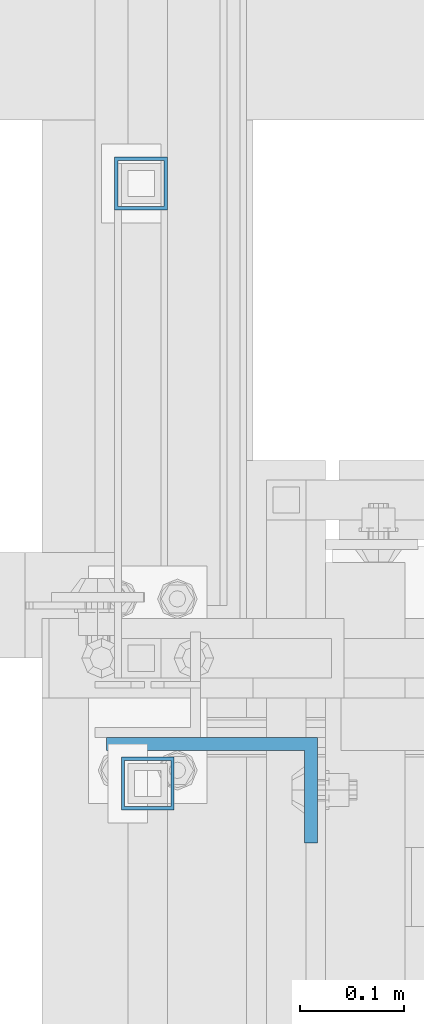
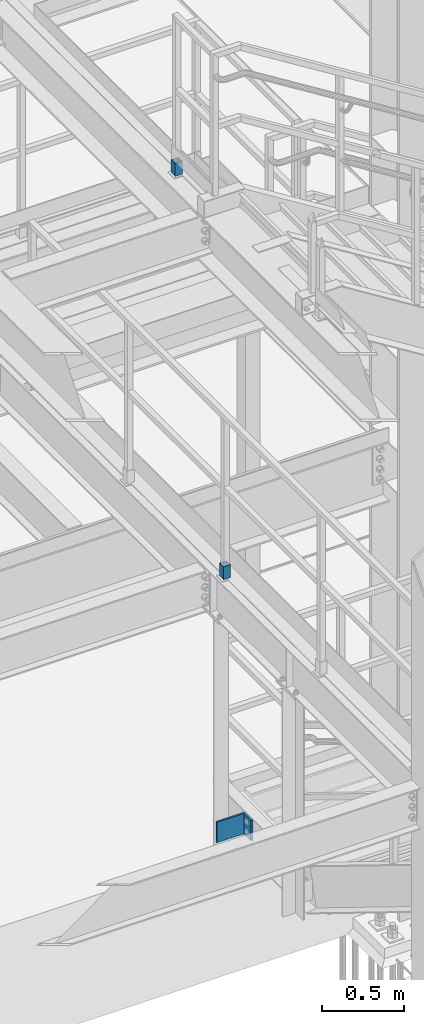
# One storey, part 1478 of 3843: 3 columns, 3 elements without a shape of their own.
"""IFC2X3 building model written with IfcOpenShell, lengths in millimetres."""

import ifcopenshell
import ifcopenshell.guid

model = None  # the IFC model being written
_history = None  # IfcOwnerHistory: only IFC2X3 demands one
_inside = {}  # id of a spatial element -> (the spatial element, [elements in it])
_under = {}  # id of a project, library or spatial element -> (it, [spatial elements below it])
_declared = {}  # id of a project -> (the project, [libraries it declares])
_typed = {}  # id of a type object -> (the type object, [elements of that type])
_made_of = {}  # id of a material, layer set ... -> (it, [elements and type objects made of it])


def new_model(schema):
    """Start an empty IFC model of exactly this schema.

    Asked for "IFC4X3", IfcOpenShell would pick the latest addendum, in which some entities
    have other attributes; the version numbers below select the first issue.
    IFC2X3 requires an IfcOwnerHistory on every rooted entity: one is made here for all.
    """
    global model, _history
    if schema == "IFC4X3":
        model = ifcopenshell.file(schema_version=(4, 3, 0, 0))
    else:
        model = ifcopenshell.file(schema=schema)
    _inside.clear()
    _under.clear()
    _declared.clear()
    _typed.clear()
    _made_of.clear()
    _history = None
    if model.schema == "IFC2X3":
        org = make("IfcOrganization", Name="unknown")
        user = make(
            "IfcPersonAndOrganization",
            ThePerson=make("IfcPerson", FamilyName="unknown"),
            TheOrganization=org,
        )
        app = make(
            "IfcApplication",
            ApplicationDeveloper=org,
            Version="unknown",
            ApplicationFullName="unknown",
            ApplicationIdentifier="unknown",
        )
        _history = make(
            "IfcOwnerHistory",
            OwningUser=user,
            OwningApplication=app,
            ChangeAction="ADDED",
            CreationDate=0,
        )
    return model


def make(cls, **values):
    """One entity of the class cls with the attributes given. An attribute that is None is left unset."""
    return model.create_entity(
        cls, **{name: value for name, value in values.items() if value is not None}
    )


def rooted(cls, **values):
    """An entity with a GlobalId (a new one), such as an element, a storey or a relation."""
    return make(cls, GlobalId=ifcopenshell.guid.new(), OwnerHistory=_history, **values)


def si_unit(unit_type, name, prefix=None):
    """IfcSIUnit, for example si_unit("LENGTHUNIT", "METRE", prefix="MILLI")."""
    return make("IfcSIUnit", UnitType=unit_type, Prefix=prefix, Name=name)


def assignment(units):
    """IfcUnitAssignment: the units of a project."""
    return None if units is None else make("IfcUnitAssignment", Units=units)


def point(xyz):
    """IfcCartesianPoint."""
    return None if xyz is None else make("IfcCartesianPoint", Coordinates=xyz)


def direction(xyz):
    """IfcDirection."""
    return None if xyz is None else make("IfcDirection", DirectionRatios=xyz)


def frame(location, z_axis=None, x_axis=None):
    """IfcAxis2Placement3D, a coordinate frame: its origin and axes. An axis left out is left unset."""
    return make(
        "IfcAxis2Placement3D",
        Location=point(location),
        Axis=direction(z_axis),
        RefDirection=direction(x_axis),
    )


def origin_with_axes():
    """The frame at (0, 0, 0) with the z axis (0, 0, 1) and the x axis (1, 0, 0) written out."""
    return frame((0.0, 0.0, 0.0), z_axis=(0.0, 0.0, 1.0), x_axis=(1.0, 0.0, 0.0))


def place(relative_to, where):
    """IfcLocalPlacement: puts the frame where relative to a parent placement (None: the world)."""
    return make(
        "IfcLocalPlacement", PlacementRelTo=relative_to, RelativePlacement=where
    )


def context(
    kind, dimensions, precision=None, world=None, true_north=None, identifier=None
):
    """IfcGeometricRepresentationContext, for example the 3D "Model" context."""
    return make(
        "IfcGeometricRepresentationContext",
        ContextIdentifier=identifier,
        ContextType=kind,
        CoordinateSpaceDimension=dimensions,
        Precision=precision,
        WorldCoordinateSystem=world,
        TrueNorth=true_north,
    )


def subcontext(parent, identifier, kind, view, scale=None):
    """IfcGeometricRepresentationSubContext, for example "Body" below "Model"."""
    return make(
        "IfcGeometricRepresentationSubContext",
        ContextIdentifier=identifier,
        ContextType=kind,
        ParentContext=parent,
        TargetScale=scale,
        TargetView=view,
    )


def project(units=None, contexts=None):
    """IfcProject with its units and contexts."""
    return rooted(
        "IfcProject",
        Name="project",
        RepresentationContexts=contexts,
        UnitsInContext=assignment(units),
    )


def spatial(cls, under=None, at=None, **own):
    """A site, building, storey or space (cls), placed at a placement, below another one or the project."""
    s = rooted(cls, ObjectPlacement=at, **own)
    if under is not None:
        _under.setdefault(under.id(), (under, []))[1].append(s)
    return s


def faces_of(points, faces, orient=None, outer=None):
    """IfcFace entities. A face is a list of loops; a loop is a list of indices into points, from 0.

    orient and outer hold one flag for each loop. By default every Orientation is true, the
    first loop of a face is its IfcFaceOuterBound and the others are IfcFaceBound.
    """
    made = []
    for i, loops in enumerate(faces):
        bounds = []
        for j, loop in enumerate(loops):
            is_outer = j == 0 if outer is None else outer[i][j]
            bounds.append(
                make(
                    "IfcFaceOuterBound" if is_outer else "IfcFaceBound",
                    Bound=make("IfcPolyLoop", Polygon=[points[k] for k in loop]),
                    Orientation=True if orient is None else orient[i][j],
                )
            )
        made.append(make("IfcFace", Bounds=bounds))
    return made


def faceted_brep(points, faces, orient=None, outer=None, voids=None):
    """IfcFacetedBrep: a solid bounded by flat faces; with voids (closed shells), ...WithVoids."""
    shared = [point(p) for p in points]
    hull = make("IfcClosedShell", CfsFaces=faces_of(shared, faces, orient, outer))
    if voids is None:
        return make("IfcFacetedBrep", Outer=hull)
    return make(
        "IfcFacetedBrepWithVoids",
        Outer=hull,
        Voids=[
            make(cls, CfsFaces=faces_of(shared, fs, o, b)) for cls, fs, o, b in voids
        ],
    )


def shape(context_of_items, identifier, shape_type, items):
    """IfcShapeRepresentation: the items that make up one representation, for example the "Body"."""
    return make(
        "IfcShapeRepresentation",
        ContextOfItems=context_of_items,
        RepresentationIdentifier=identifier,
        RepresentationType=shape_type,
        Items=items,
    )


def material(Name=None, Category=None):
    """IfcMaterial."""
    return make("IfcMaterial", Name=Name, Category=Category)


def made_of(thing, what):
    """Note that an element or type object is made of a material, layer set ...; save() writes the relation."""
    if what is not None:
        _made_of.setdefault(what.id(), (what, []))[1].append(thing)
    return thing


def type_object(cls, material=None, **own):
    """A type object (cls), such as IfcWallType, which elements share."""
    return made_of(rooted(cls, **own), material)


def element(
    cls,
    number,
    at=None,
    inside=None,
    cuts=None,
    type_object=None,
    material=None,
    context=None,
    identifier="Body",
    shape_type=None,
    held_by="IfcProductDefinitionShape",
    body=None,
    shapes=None,
    **own,
):
    """One element of the class cls, such as IfcWall. Its Tag is "e" and its number.

    at: its placement. inside: the storey or other place that contains it. cuts: it is an
    opening in that element (IfcRelVoidsElement). A single representation is given by context,
    identifier, shape_type and body (its items); several are given by shapes. held_by: the class
    of the entity that holds the representations. save() writes the other relations.
    """
    e = rooted(cls, Tag="e%d" % number, ObjectPlacement=at, **own)
    if body is not None:
        shapes = [shape(context, identifier, shape_type, body)]
    if shapes is not None:
        e.Representation = make(held_by, Representations=shapes)
    if inside is not None:
        _inside.setdefault(inside.id(), (inside, []))[1].append(e)
    if cuts is not None:
        rooted(
            "IfcRelVoidsElement", RelatingBuildingElement=cuts, RelatedOpeningElement=e
        )
    if type_object is not None:
        _typed.setdefault(type_object.id(), (type_object, []))[1].append(e)
    return made_of(e, material)


def aggregate(whole, parts):
    """IfcRelAggregates: a whole, such as a stair, and the parts it consists of."""
    return rooted("IfcRelAggregates", RelatingObject=whole, RelatedObjects=parts)


def save(model, path):
    """Write the relations noted so far, then the file.

    IfcRelAggregates (storeys below a building ...), IfcRelContainedInSpatialStructure (elements
    in a storey), IfcRelDefinesByType, IfcRelAssociatesMaterial and IfcRelDeclares: one each for
    every whole, place, type object, material and project.
    """
    for whole, parts in _under.values():
        aggregate(whole, parts)
    for where, things in _inside.values():
        rooted(
            "IfcRelContainedInSpatialStructure",
            RelatedElements=things,
            RelatingStructure=where,
        )
    for kind, things in _typed.values():
        rooted("IfcRelDefinesByType", RelatedObjects=things, RelatingType=kind)
    for what, things in _made_of.values():
        rooted("IfcRelAssociatesMaterial", RelatedObjects=things, RelatingMaterial=what)
    for by, libraries in _declared.values():
        rooted("IfcRelDeclares", RelatingContext=by, RelatedDefinitions=libraries)
    model.write(path)


model = new_model("IFC2X3")

# Units and contexts
model_context = context("Model", 3, precision=1e-05, world=origin_with_axes())
body_context = subcontext(model_context, "Body", "Model", "MODEL_VIEW")
ifc_project = project(units=[si_unit("LENGTHUNIT", "METRE", prefix="MILLI"), si_unit("AREAUNIT", "SQUARE_METRE"), si_unit("VOLUMEUNIT", "CUBIC_METRE"), si_unit("MASSUNIT", "GRAM", prefix="KILO"), si_unit("TIMEUNIT", "SECOND"), si_unit("PLANEANGLEUNIT", "RADIAN"), si_unit("SOLIDANGLEUNIT", "STERADIAN"), si_unit("THERMODYNAMICTEMPERATUREUNIT", "DEGREE_CELSIUS"), si_unit("LUMINOUSINTENSITYUNIT", "LUMEN")], contexts=[model_context])

# Site, building, storey
site_placement = place(None, origin_with_axes())
site = spatial("IfcSite", under=ifc_project, at=site_placement, CompositionType="ELEMENT")
building_placement = place(site_placement, origin_with_axes())
building = spatial("IfcBuilding", under=site, at=building_placement, Name="Undefined", CompositionType="ELEMENT")
storey_placement = place(building_placement, origin_with_axes())
storey = spatial("IfcBuildingStorey", under=building, at=storey_placement, Name="Undefined", CompositionType="ELEMENT", Elevation=0.0)

# Assembly, column
assembly_1_placement = place(storey_placement, origin_with_axes())
assembly_1 = element("IfcElementAssembly", 1, at=assembly_1_placement, inside=storey, Name="BEAM", AssemblyPlace="NOTDEFINED", PredefinedType="RIGID_FRAME")
ifc_material_1 = material()
column_type_1 = type_object("IfcColumnType", Name="HSS2X2X1/8", PredefinedType="NOTDEFINED")
column_1_placement = place(assembly_1_placement, frame((52990.75, 22790.1499996175, 34817.05), z_axis=(1.0, 0.0, 0.0), x_axis=(0.0, 0.0, 1.0)))
column_1 = element("IfcColumn", 2, at=column_1_placement, type_object=column_type_1, material=ifc_material_1, Name="POST_SLEEVE", ObjectType="HSS2X2X1/8", context=body_context, shape_type="Brep", body=[
    faceted_brep([(0.0, 22.2249999999985, -22.2249999999985), (0.0, -22.2249999999985, -22.2249999999985), (95.25, -22.2249999999985, -22.2249999999985), (95.25, 22.2249999999985, -22.2249999999985), (0.0, -22.2249999999985, 22.2249999999985), (95.25, -22.2249999999985, 22.2249999999985), (0.0, 22.2249999999985, 22.2249999999985), (95.25, 22.2249999999985, 22.2249999999985), (0.0, 25.4000000000015, -25.4000000000015), (0.0, 25.4000000000015, 25.4000000000015), (95.25, 25.4000000000015, 25.4000000000015), (95.25, 25.4000000000015, -25.4000000000015), (0.0, -25.4000000000015, 25.4000000000015), (95.25, -25.4000000000015, 25.4000000000015), (0.0, -25.4000000000015, -25.4000000000015), (95.25, -25.4000000000015, -25.4000000000015)], [[[0, 1, 2, 3]], [[1, 4, 5, 2]], [[4, 6, 7, 5]], [[6, 0, 3, 7]], [[8, 9, 10, 11]], [[9, 12, 13, 10]], [[12, 14, 15, 13]], [[14, 8, 11, 15]], [[13, 15, 11, 10], [5, 7, 3, 2]], [[14, 12, 9, 8], [6, 4, 1, 0]]]),
])
aggregate(assembly_1, [column_1])

assembly_2_placement = place(storey_placement, origin_with_axes())
assembly_2 = element("IfcElementAssembly", 3, at=assembly_2_placement, inside=storey, Name="BEAM", AssemblyPlace="NOTDEFINED", PredefinedType="RIGID_FRAME")
column_2_placement = place(assembly_2_placement, frame((52984.3999999344, 23368.0000000151, 37471.35), z_axis=(1.0, 0.0, 0.0), x_axis=(0.0, 0.0, 1.0)))
column_2 = element("IfcColumn", 4, at=column_2_placement, type_object=column_type_1, material=ifc_material_1, Name="POST_SLEEVE", ObjectType="HSS2X2X1/8", context=body_context, shape_type="Brep", body=[
    faceted_brep([(0.0, 22.2249999999985, -22.2249999999985), (0.0, -22.2249999999985, -22.2249999999985), (95.25, -22.2249999999985, -22.2249999999985), (95.25, 22.2249999999985, -22.2249999999985), (0.0, -22.2249999999985, 22.2249999999985), (95.25, -22.2249999999985, 22.2249999999985), (0.0, 22.2249999999985, 22.2249999999985), (95.25, 22.2249999999985, 22.2249999999985), (0.0, 25.4000000000015, -25.4000000000015), (0.0, 25.4000000000015, 25.4000000000015), (95.25, 25.4000000000015, 25.4000000000015), (95.25, 25.4000000000015, -25.4000000000015), (0.0, -25.4000000000015, 25.4000000000015), (95.25, -25.4000000000015, 25.4000000000015), (0.0, -25.4000000000015, -25.4000000000015), (95.25, -25.4000000000015, -25.4000000000015)], [[[0, 1, 2, 3]], [[1, 4, 5, 2]], [[4, 6, 7, 5]], [[6, 0, 3, 7]], [[8, 9, 10, 11]], [[9, 12, 13, 10]], [[12, 14, 15, 13]], [[14, 8, 11, 15]], [[13, 15, 11, 10], [5, 7, 3, 2]], [[14, 12, 9, 8], [6, 4, 1, 0]]]),
])
aggregate(assembly_2, [column_2])

assembly_3_placement = place(storey_placement, origin_with_axes())
assembly_3 = element("IfcElementAssembly", 5, at=assembly_3_placement, inside=storey, Name="HANGER", AssemblyPlace="NOTDEFINED", PredefinedType="RIGID_FRAME")
ifc_material_2 = material(Name="STEEL/A36")
column_type_2 = type_object("IfcColumnType", Name="L8X4X1/2", PredefinedType="NOTDEFINED")
column_3_placement = place(assembly_3_placement, frame((53052.662, 22783.8, 32830.4769213273), z_axis=(-1.0, 0.0, 0.0), x_axis=(0.0, 0.0, 1.0)))
column_3 = element("IfcColumn", 6, at=column_3_placement, type_object=column_type_2, material=ifc_material_2, Name="ANGLE", ObjectType="L8X4X1/2", context=body_context, shape_type="Brep", body=[
    faceted_brep([(0.0, 50.7999999999993, -101.599999999999), (0.0, 50.7999999999993, 101.599999999999), (152.399999999994, 50.7999999999993, 101.599999999999), (152.399999999994, 50.7999999999993, -101.599999999999), (0.0, 38.0999999999985, 101.599999999999), (152.399999999994, 38.0999999999985, 101.599999999999), (0.0, 38.0999999999985, -88.9000000000015), (152.399999999994, 38.0999999999985, -88.9000000000015), (0.0, -50.7999999999993, -88.9000000000015), (152.399999999994, -50.7999999999993, -88.9000000000015), (0.0, -50.7999999999993, -101.599999999999), (152.399999999994, -50.7999999999993, -101.599999999999)], [[[0, 1, 2, 3]], [[1, 4, 5, 2]], [[4, 6, 7, 5]], [[6, 8, 9, 7]], [[8, 10, 11, 9]], [[10, 0, 3, 11]], [[5, 7, 9, 11, 3, 2]], [[10, 8, 6, 4, 1, 0]]]),
])
aggregate(assembly_3, [column_3])

save(model, "model.ifc")
